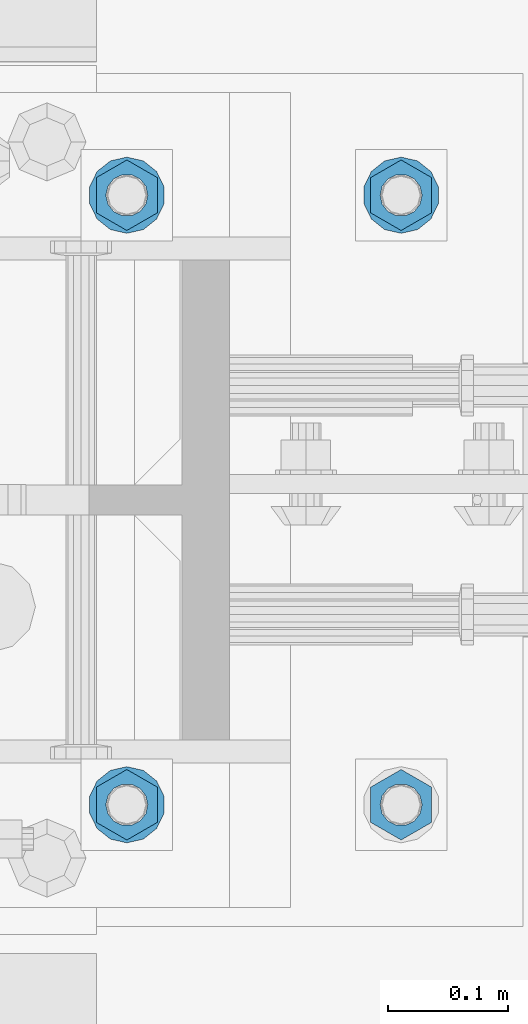
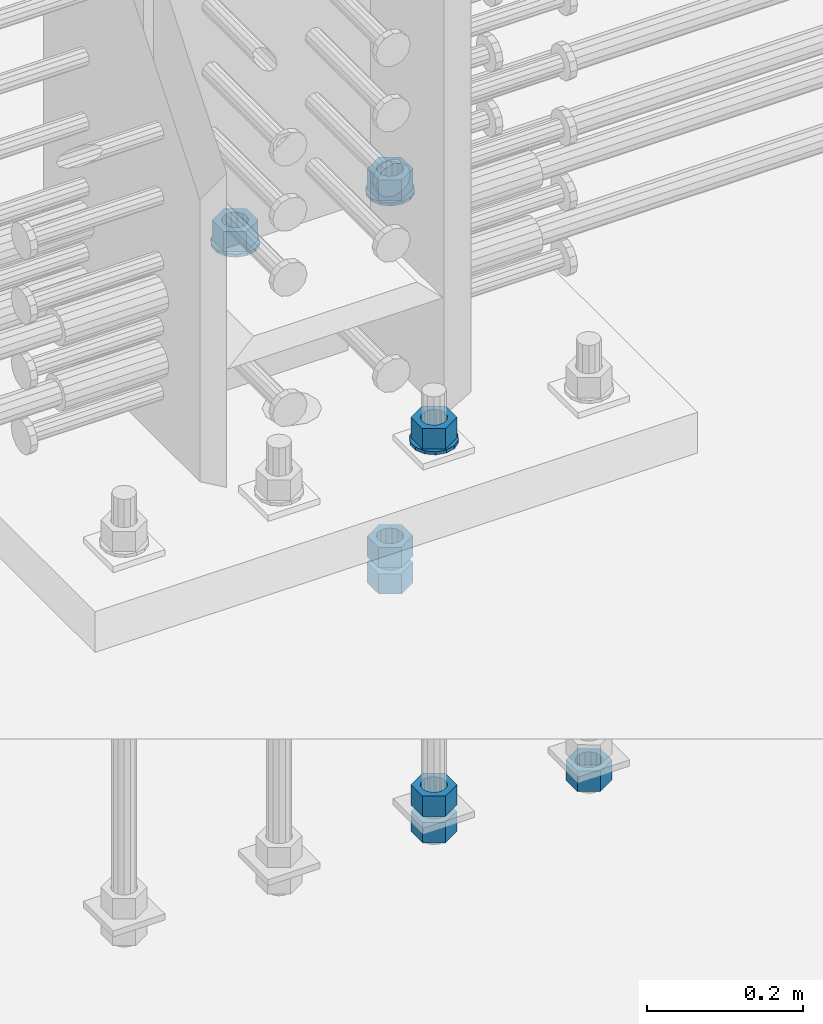
# One storey, part 1004 of 1763: 11 columns, 1 element without a shape of its own.
"""IFC2X3 building model written with IfcOpenShell, lengths in millimetres."""

import ifcopenshell
import ifcopenshell.guid

model = None  # the IFC model being written
_history = None  # IfcOwnerHistory: only IFC2X3 demands one
_inside = {}  # id of a spatial element -> (the spatial element, [elements in it])
_under = {}  # id of a project, library or spatial element -> (it, [spatial elements below it])
_declared = {}  # id of a project -> (the project, [libraries it declares])
_typed = {}  # id of a type object -> (the type object, [elements of that type])
_made_of = {}  # id of a material, layer set ... -> (it, [elements and type objects made of it])


def new_model(schema):
    """Start an empty IFC model of exactly this schema.

    Asked for "IFC4X3", IfcOpenShell would pick the latest addendum, in which some entities
    have other attributes; the version numbers below select the first issue.
    IFC2X3 requires an IfcOwnerHistory on every rooted entity: one is made here for all.
    """
    global model, _history
    if schema == "IFC4X3":
        model = ifcopenshell.file(schema_version=(4, 3, 0, 0))
    else:
        model = ifcopenshell.file(schema=schema)
    _inside.clear()
    _under.clear()
    _declared.clear()
    _typed.clear()
    _made_of.clear()
    _history = None
    if model.schema == "IFC2X3":
        org = make("IfcOrganization", Name="unknown")
        user = make(
            "IfcPersonAndOrganization",
            ThePerson=make("IfcPerson", FamilyName="unknown"),
            TheOrganization=org,
        )
        app = make(
            "IfcApplication",
            ApplicationDeveloper=org,
            Version="unknown",
            ApplicationFullName="unknown",
            ApplicationIdentifier="unknown",
        )
        _history = make(
            "IfcOwnerHistory",
            OwningUser=user,
            OwningApplication=app,
            ChangeAction="ADDED",
            CreationDate=0,
        )
    return model


def make(cls, **values):
    """One entity of the class cls with the attributes given. An attribute that is None is left unset."""
    return model.create_entity(
        cls, **{name: value for name, value in values.items() if value is not None}
    )


def rooted(cls, **values):
    """An entity with a GlobalId (a new one), such as an element, a storey or a relation."""
    return make(cls, GlobalId=ifcopenshell.guid.new(), OwnerHistory=_history, **values)


def si_unit(unit_type, name, prefix=None):
    """IfcSIUnit, for example si_unit("LENGTHUNIT", "METRE", prefix="MILLI")."""
    return make("IfcSIUnit", UnitType=unit_type, Prefix=prefix, Name=name)


def assignment(units):
    """IfcUnitAssignment: the units of a project."""
    return None if units is None else make("IfcUnitAssignment", Units=units)


def point(xyz):
    """IfcCartesianPoint."""
    return None if xyz is None else make("IfcCartesianPoint", Coordinates=xyz)


def direction(xyz):
    """IfcDirection."""
    return None if xyz is None else make("IfcDirection", DirectionRatios=xyz)


def frame(location, z_axis=None, x_axis=None):
    """IfcAxis2Placement3D, a coordinate frame: its origin and axes. An axis left out is left unset."""
    return make(
        "IfcAxis2Placement3D",
        Location=point(location),
        Axis=direction(z_axis),
        RefDirection=direction(x_axis),
    )


def origin_with_axes():
    """The frame at (0, 0, 0) with the z axis (0, 0, 1) and the x axis (1, 0, 0) written out."""
    return frame((0.0, 0.0, 0.0), z_axis=(0.0, 0.0, 1.0), x_axis=(1.0, 0.0, 0.0))


def place(relative_to, where):
    """IfcLocalPlacement: puts the frame where relative to a parent placement (None: the world)."""
    return make(
        "IfcLocalPlacement", PlacementRelTo=relative_to, RelativePlacement=where
    )


def context(
    kind, dimensions, precision=None, world=None, true_north=None, identifier=None
):
    """IfcGeometricRepresentationContext, for example the 3D "Model" context."""
    return make(
        "IfcGeometricRepresentationContext",
        ContextIdentifier=identifier,
        ContextType=kind,
        CoordinateSpaceDimension=dimensions,
        Precision=precision,
        WorldCoordinateSystem=world,
        TrueNorth=true_north,
    )


def subcontext(parent, identifier, kind, view, scale=None):
    """IfcGeometricRepresentationSubContext, for example "Body" below "Model"."""
    return make(
        "IfcGeometricRepresentationSubContext",
        ContextIdentifier=identifier,
        ContextType=kind,
        ParentContext=parent,
        TargetScale=scale,
        TargetView=view,
    )


def project(units=None, contexts=None):
    """IfcProject with its units and contexts."""
    return rooted(
        "IfcProject",
        Name="project",
        RepresentationContexts=contexts,
        UnitsInContext=assignment(units),
    )


def spatial(cls, under=None, at=None, **own):
    """A site, building, storey or space (cls), placed at a placement, below another one or the project."""
    s = rooted(cls, ObjectPlacement=at, **own)
    if under is not None:
        _under.setdefault(under.id(), (under, []))[1].append(s)
    return s


def faces_of(points, faces, orient=None, outer=None):
    """IfcFace entities. A face is a list of loops; a loop is a list of indices into points, from 0.

    orient and outer hold one flag for each loop. By default every Orientation is true, the
    first loop of a face is its IfcFaceOuterBound and the others are IfcFaceBound.
    """
    made = []
    for i, loops in enumerate(faces):
        bounds = []
        for j, loop in enumerate(loops):
            is_outer = j == 0 if outer is None else outer[i][j]
            bounds.append(
                make(
                    "IfcFaceOuterBound" if is_outer else "IfcFaceBound",
                    Bound=make("IfcPolyLoop", Polygon=[points[k] for k in loop]),
                    Orientation=True if orient is None else orient[i][j],
                )
            )
        made.append(make("IfcFace", Bounds=bounds))
    return made


def faceted_brep(points, faces, orient=None, outer=None, voids=None):
    """IfcFacetedBrep: a solid bounded by flat faces; with voids (closed shells), ...WithVoids."""
    shared = [point(p) for p in points]
    hull = make("IfcClosedShell", CfsFaces=faces_of(shared, faces, orient, outer))
    if voids is None:
        return make("IfcFacetedBrep", Outer=hull)
    return make(
        "IfcFacetedBrepWithVoids",
        Outer=hull,
        Voids=[
            make(cls, CfsFaces=faces_of(shared, fs, o, b)) for cls, fs, o, b in voids
        ],
    )


def shape(context_of_items, identifier, shape_type, items):
    """IfcShapeRepresentation: the items that make up one representation, for example the "Body"."""
    return make(
        "IfcShapeRepresentation",
        ContextOfItems=context_of_items,
        RepresentationIdentifier=identifier,
        RepresentationType=shape_type,
        Items=items,
    )


def material(Name=None, Category=None):
    """IfcMaterial."""
    return make("IfcMaterial", Name=Name, Category=Category)


def made_of(thing, what):
    """Note that an element or type object is made of a material, layer set ...; save() writes the relation."""
    if what is not None:
        _made_of.setdefault(what.id(), (what, []))[1].append(thing)
    return thing


def type_object(cls, material=None, **own):
    """A type object (cls), such as IfcWallType, which elements share."""
    return made_of(rooted(cls, **own), material)


def element(
    cls,
    number,
    at=None,
    inside=None,
    cuts=None,
    type_object=None,
    material=None,
    context=None,
    identifier="Body",
    shape_type=None,
    held_by="IfcProductDefinitionShape",
    body=None,
    shapes=None,
    **own,
):
    """One element of the class cls, such as IfcWall. Its Tag is "e" and its number.

    at: its placement. inside: the storey or other place that contains it. cuts: it is an
    opening in that element (IfcRelVoidsElement). A single representation is given by context,
    identifier, shape_type and body (its items); several are given by shapes. held_by: the class
    of the entity that holds the representations. save() writes the other relations.
    """
    e = rooted(cls, Tag="e%d" % number, ObjectPlacement=at, **own)
    if body is not None:
        shapes = [shape(context, identifier, shape_type, body)]
    if shapes is not None:
        e.Representation = make(held_by, Representations=shapes)
    if inside is not None:
        _inside.setdefault(inside.id(), (inside, []))[1].append(e)
    if cuts is not None:
        rooted(
            "IfcRelVoidsElement", RelatingBuildingElement=cuts, RelatedOpeningElement=e
        )
    if type_object is not None:
        _typed.setdefault(type_object.id(), (type_object, []))[1].append(e)
    return made_of(e, material)


def aggregate(whole, parts):
    """IfcRelAggregates: a whole, such as a stair, and the parts it consists of."""
    return rooted("IfcRelAggregates", RelatingObject=whole, RelatedObjects=parts)


def save(model, path):
    """Write the relations noted so far, then the file.

    IfcRelAggregates (storeys below a building ...), IfcRelContainedInSpatialStructure (elements
    in a storey), IfcRelDefinesByType, IfcRelAssociatesMaterial and IfcRelDeclares: one each for
    every whole, place, type object, material and project.
    """
    for whole, parts in _under.values():
        aggregate(whole, parts)
    for where, things in _inside.values():
        rooted(
            "IfcRelContainedInSpatialStructure",
            RelatedElements=things,
            RelatingStructure=where,
        )
    for kind, things in _typed.values():
        rooted("IfcRelDefinesByType", RelatedObjects=things, RelatingType=kind)
    for what, things in _made_of.values():
        rooted("IfcRelAssociatesMaterial", RelatedObjects=things, RelatingMaterial=what)
    for by, libraries in _declared.values():
        rooted("IfcRelDeclares", RelatingContext=by, RelatedDefinitions=libraries)
    model.write(path)


model = new_model("IFC2X3")

# Units and contexts
model_context = context("Model", 3, precision=1e-05, world=origin_with_axes())
body_context = subcontext(model_context, "Body", "Model", "MODEL_VIEW")
ifc_project = project(units=[si_unit("LENGTHUNIT", "METRE", prefix="MILLI"), si_unit("AREAUNIT", "SQUARE_METRE"), si_unit("VOLUMEUNIT", "CUBIC_METRE"), si_unit("MASSUNIT", "GRAM", prefix="KILO"), si_unit("TIMEUNIT", "SECOND"), si_unit("PLANEANGLEUNIT", "RADIAN"), si_unit("SOLIDANGLEUNIT", "STERADIAN"), si_unit("THERMODYNAMICTEMPERATUREUNIT", "DEGREE_CELSIUS"), si_unit("LUMINOUSINTENSITYUNIT", "LUMEN")], contexts=[model_context])

# Site, building, storey
site_placement = place(None, origin_with_axes())
site = spatial("IfcSite", under=ifc_project, at=site_placement, CompositionType="ELEMENT")
building_placement = place(site_placement, origin_with_axes())
building = spatial("IfcBuilding", under=site, at=building_placement, Name="Undefined", CompositionType="ELEMENT")
storey_placement = place(building_placement, origin_with_axes())
storey = spatial("IfcBuildingStorey", under=building, at=storey_placement, Name="Undefined", CompositionType="ELEMENT", Elevation=0.0)

# Assembly, columns
assembly_placement = place(storey_placement, origin_with_axes())
assembly = element("IfcElementAssembly", 1, at=assembly_placement, inside=storey, Name="TEMPLATE", AssemblyPlace="NOTDEFINED", PredefinedType="RIGID_FRAME")
ifc_material_1 = material(Name="STEEL/A563")
column_type_1 = type_object("IfcColumnType", Name="1-1/4_HEAVY_HEX_NUT", PredefinedType="NOTDEFINED")
column_1_placement = place(assembly_placement, frame((-34606.937273698, 203.199999999951, 3343.275), z_axis=(1.0, 0.0, 0.0), x_axis=(0.0, 0.0, -1.0)))
column_1 = element("IfcColumn", 2, at=column_1_placement, type_object=column_type_1, material=ifc_material_1, Name="NUT", ObjectType="1-1/4_HEAVY_HEX_NUT", context=body_context, shape_type="Brep", body=[
    faceted_brep([(0.0, -29.3700008392334, 0.0), (0.0, -14.6800003051758, -25.4300003051758), (31.75, -14.6800003051758, -25.4300003051758), (31.75, -29.3700008392334, 0.0), (0.0, 14.6800003051758, -25.4300003051758), (31.75, 14.6800003051758, -25.4300003051758), (0.0, 29.3700008392334, 0.0), (31.75, 29.3700008392334, 0.0), (0.0, 14.6800003051758, 25.4300003051758), (31.75, 14.6800003051758, 25.4300003051758), (0.0, -14.6800003051758, 25.4300003051758), (31.75, -14.6800003051758, 25.4300003051758), (0.0, 0.0, 17.4599990844727), (0.0, 7.57560968776022, 15.730915608714), (31.75, 7.57560968775942, 15.7309156087145), (31.75, 0.0, 17.4599990844727), (0.0, 13.6507769681037, 10.8861313696252), (31.75, 13.6507769681048, 10.8861313696314), (0.0, 17.0222404541215, 3.88521530314756), (31.75, 17.02224045412, 3.88521530315316), (0.0, 17.0222404541215, -3.88521530314756), (31.75, 17.02224045412, -3.88521530315332), (0.0, 13.6507769681037, -10.8861313696252), (31.75, 13.6507769681048, -10.8861313696316), (0.0, 7.57560968776022, -15.730915608714), (31.75, 7.57560968775942, -15.7309156087146), (0.0, 0.0, -17.4599990844727), (31.75, 0.0, -17.4599990844727), (0.0, -7.57560968776022, -15.730915608714), (31.75, -7.57560968775942, -15.7309156087145), (0.0, -13.6507769681037, -10.8861313696252), (31.75, -13.6507769681048, -10.8861313696314), (0.0, -17.0222404541215, -3.88521530314756), (31.75, -17.02224045412, -3.88521530315316), (0.0, -17.0222404541215, 3.88521530314756), (31.75, -17.02224045412, 3.88521530315332), (0.0, -13.6507769681037, 10.8861313696252), (31.75, -13.6507769681048, 10.8861313696316), (0.0, -7.57560968776022, 15.730915608714), (31.75, -7.57560968775942, 15.7309156087146)], [[[0, 1, 2, 3]], [[1, 4, 5, 2]], [[4, 6, 7, 5]], [[6, 8, 9, 7]], [[8, 10, 11, 9]], [[10, 0, 3, 11]], [[12, 13, 14, 15]], [[13, 16, 17, 14]], [[16, 18, 19, 17]], [[18, 20, 21, 19]], [[20, 22, 23, 21]], [[22, 24, 25, 23]], [[24, 26, 27, 25]], [[26, 28, 29, 27]], [[28, 30, 31, 29]], [[30, 32, 33, 31]], [[32, 34, 35, 33]], [[34, 36, 37, 35]], [[36, 38, 39, 37]], [[38, 12, 15, 39]], [[5, 7, 9, 11, 3, 2], [17, 19, 21, 23, 25, 27, 29, 31, 33, 35, 37, 39, 15, 14]], [[10, 8, 6, 4, 1, 0], [38, 36, 34, 32, 30, 28, 26, 24, 22, 20, 18, 16, 13, 12]]]),
])
column_2_placement = place(assembly_placement, frame((-34606.937273698, 711.199999999951, 3957.6375), z_axis=(-1.0, 0.0, 0.0), x_axis=(0.0, 0.0, -1.0)))
column_2 = element("IfcColumn", 3, at=column_2_placement, type_object=column_type_1, material=ifc_material_1, Name="NUT", ObjectType="1-1/4_HEAVY_HEX_NUT", context=body_context, shape_type="Brep", body=[
    faceted_brep([(0.0, -29.3700008392334, 0.0), (0.0, -14.6800003051758, -25.4300003051758), (31.75, -14.6800003051758, -25.4300003051758), (31.75, -29.3700008392334, 0.0), (0.0, 14.6800003051758, -25.4300003051758), (31.75, 14.6800003051758, -25.4300003051758), (0.0, 29.3700008392334, 0.0), (31.75, 29.3700008392334, 0.0), (0.0, 14.6800003051758, 25.4300003051758), (31.75, 14.6800003051758, 25.4300003051758), (0.0, -14.6800003051758, 25.4300003051758), (31.75, -14.6800003051758, 25.4300003051758), (0.0, 0.0, 17.4599990844727), (0.0, 7.57560968776022, 15.730915608714), (31.75, 7.57560968775942, 15.7309156087145), (31.75, 0.0, 17.4599990844727), (0.0, 13.6507769681037, 10.8861313696252), (31.75, 13.6507769681048, 10.8861313696314), (0.0, 17.0222404541215, 3.88521530314756), (31.75, 17.02224045412, 3.88521530315316), (0.0, 17.0222404541215, -3.88521530314756), (31.75, 17.02224045412, -3.88521530315332), (0.0, 13.6507769681037, -10.8861313696252), (31.75, 13.6507769681048, -10.8861313696316), (0.0, 7.57560968776022, -15.730915608714), (31.75, 7.57560968775942, -15.7309156087146), (0.0, 0.0, -17.4599990844727), (31.75, 0.0, -17.4599990844727), (0.0, -7.57560968776022, -15.730915608714), (31.75, -7.57560968775942, -15.7309156087145), (0.0, -13.6507769681037, -10.8861313696252), (31.75, -13.6507769681048, -10.8861313696314), (0.0, -17.0222404541215, -3.88521530314756), (31.75, -17.02224045412, -3.88521530315316), (0.0, -17.0222404541215, 3.88521530314756), (31.75, -17.02224045412, 3.88521530315332), (0.0, -13.6507769681037, 10.8861313696252), (31.75, -13.6507769681048, 10.8861313696316), (0.0, -7.57560968776022, 15.730915608714), (31.75, -7.57560968775942, 15.7309156087146)], [[[0, 1, 2, 3]], [[1, 4, 5, 2]], [[4, 6, 7, 5]], [[6, 8, 9, 7]], [[8, 10, 11, 9]], [[10, 0, 3, 11]], [[12, 13, 14, 15]], [[13, 16, 17, 14]], [[16, 18, 19, 17]], [[18, 20, 21, 19]], [[20, 22, 23, 21]], [[22, 24, 25, 23]], [[24, 26, 27, 25]], [[26, 28, 29, 27]], [[28, 30, 31, 29]], [[30, 32, 33, 31]], [[32, 34, 35, 33]], [[34, 36, 37, 35]], [[36, 38, 39, 37]], [[38, 12, 15, 39]], [[5, 7, 9, 11, 3, 2], [17, 19, 21, 23, 25, 27, 29, 31, 33, 35, 37, 39, 15, 14]], [[10, 8, 6, 4, 1, 0], [38, 36, 34, 32, 30, 28, 26, 24, 22, 20, 18, 16, 13, 12]]]),
])
column_3_placement = place(assembly_placement, frame((-34606.937273698, 711.199999999951, 3384.55), z_axis=(-1.0, 0.0, 0.0), x_axis=(0.0, 0.0, -1.0)))
column_3 = element("IfcColumn", 4, at=column_3_placement, type_object=column_type_1, material=ifc_material_1, Name="NUT", ObjectType="1-1/4_HEAVY_HEX_NUT", context=body_context, shape_type="Brep", body=[
    faceted_brep([(0.0, -29.3700008392334, 0.0), (0.0, -14.6800003051758, -25.4300003051758), (31.75, -14.6800003051758, -25.4300003051758), (31.75, -29.3700008392334, 0.0), (0.0, 14.6800003051758, -25.4300003051758), (31.75, 14.6800003051758, -25.4300003051758), (0.0, 29.3700008392334, 0.0), (31.75, 29.3700008392334, 0.0), (0.0, 14.6800003051758, 25.4300003051758), (31.75, 14.6800003051758, 25.4300003051758), (0.0, -14.6800003051758, 25.4300003051758), (31.75, -14.6800003051758, 25.4300003051758), (0.0, 0.0, 17.4599990844727), (0.0, 7.57560968776022, 15.730915608714), (31.75, 7.57560968775942, 15.7309156087145), (31.75, 0.0, 17.4599990844727), (0.0, 13.6507769681037, 10.8861313696252), (31.75, 13.6507769681048, 10.8861313696314), (0.0, 17.0222404541215, 3.88521530314756), (31.75, 17.02224045412, 3.88521530315316), (0.0, 17.0222404541215, -3.88521530314756), (31.75, 17.02224045412, -3.88521530315332), (0.0, 13.6507769681037, -10.8861313696252), (31.75, 13.6507769681048, -10.8861313696316), (0.0, 7.57560968776022, -15.730915608714), (31.75, 7.57560968775942, -15.7309156087146), (0.0, 0.0, -17.4599990844727), (31.75, 0.0, -17.4599990844727), (0.0, -7.57560968776022, -15.730915608714), (31.75, -7.57560968775942, -15.7309156087145), (0.0, -13.6507769681037, -10.8861313696252), (31.75, -13.6507769681048, -10.8861313696314), (0.0, -17.0222404541215, -3.88521530314756), (31.75, -17.02224045412, -3.88521530315316), (0.0, -17.0222404541215, 3.88521530314756), (31.75, -17.02224045412, 3.88521530315332), (0.0, -13.6507769681037, 10.8861313696252), (31.75, -13.6507769681048, 10.8861313696316), (0.0, -7.57560968776022, 15.730915608714), (31.75, -7.57560968775942, 15.7309156087146)], [[[0, 1, 2, 3]], [[1, 4, 5, 2]], [[4, 6, 7, 5]], [[6, 8, 9, 7]], [[8, 10, 11, 9]], [[10, 0, 3, 11]], [[12, 13, 14, 15]], [[13, 16, 17, 14]], [[16, 18, 19, 17]], [[18, 20, 21, 19]], [[20, 22, 23, 21]], [[22, 24, 25, 23]], [[24, 26, 27, 25]], [[26, 28, 29, 27]], [[28, 30, 31, 29]], [[30, 32, 33, 31]], [[32, 34, 35, 33]], [[34, 36, 37, 35]], [[36, 38, 39, 37]], [[38, 12, 15, 39]], [[5, 7, 9, 11, 3, 2], [17, 19, 21, 23, 25, 27, 29, 31, 33, 35, 37, 39, 15, 14]], [[10, 8, 6, 4, 1, 0], [38, 36, 34, 32, 30, 28, 26, 24, 22, 20, 18, 16, 13, 12]]]),
])
column_4_placement = place(assembly_placement, frame((-34606.937273698, 711.199999999951, 3343.275), z_axis=(-1.0, 0.0, 0.0), x_axis=(0.0, 0.0, -1.0)))
column_4 = element("IfcColumn", 5, at=column_4_placement, type_object=column_type_1, material=ifc_material_1, Name="NUT", ObjectType="1-1/4_HEAVY_HEX_NUT", context=body_context, shape_type="Brep", body=[
    faceted_brep([(0.0, -29.3700008392334, 0.0), (0.0, -14.6800003051758, -25.4300003051758), (31.75, -14.6800003051758, -25.4300003051758), (31.75, -29.3700008392334, 0.0), (0.0, 14.6800003051758, -25.4300003051758), (31.75, 14.6800003051758, -25.4300003051758), (0.0, 29.3700008392334, 0.0), (31.75, 29.3700008392334, 0.0), (0.0, 14.6800003051758, 25.4300003051758), (31.75, 14.6800003051758, 25.4300003051758), (0.0, -14.6800003051758, 25.4300003051758), (31.75, -14.6800003051758, 25.4300003051758), (0.0, 0.0, 17.4599990844727), (0.0, 7.57560968776022, 15.730915608714), (31.75, 7.57560968775942, 15.7309156087145), (31.75, 0.0, 17.4599990844727), (0.0, 13.6507769681037, 10.8861313696252), (31.75, 13.6507769681048, 10.8861313696314), (0.0, 17.0222404541215, 3.88521530314756), (31.75, 17.02224045412, 3.88521530315316), (0.0, 17.0222404541215, -3.88521530314756), (31.75, 17.02224045412, -3.88521530315332), (0.0, 13.6507769681037, -10.8861313696252), (31.75, 13.6507769681048, -10.8861313696316), (0.0, 7.57560968776022, -15.730915608714), (31.75, 7.57560968775942, -15.7309156087146), (0.0, 0.0, -17.4599990844727), (31.75, 0.0, -17.4599990844727), (0.0, -7.57560968776022, -15.730915608714), (31.75, -7.57560968775942, -15.7309156087145), (0.0, -13.6507769681037, -10.8861313696252), (31.75, -13.6507769681048, -10.8861313696314), (0.0, -17.0222404541215, -3.88521530314756), (31.75, -17.02224045412, -3.88521530315316), (0.0, -17.0222404541215, 3.88521530314756), (31.75, -17.02224045412, 3.88521530315332), (0.0, -13.6507769681037, 10.8861313696252), (31.75, -13.6507769681048, 10.8861313696316), (0.0, -7.57560968776022, 15.730915608714), (31.75, -7.57560968775942, 15.7309156087146)], [[[0, 1, 2, 3]], [[1, 4, 5, 2]], [[4, 6, 7, 5]], [[6, 8, 9, 7]], [[8, 10, 11, 9]], [[10, 0, 3, 11]], [[12, 13, 14, 15]], [[13, 16, 17, 14]], [[16, 18, 19, 17]], [[18, 20, 21, 19]], [[20, 22, 23, 21]], [[22, 24, 25, 23]], [[24, 26, 27, 25]], [[26, 28, 29, 27]], [[28, 30, 31, 29]], [[30, 32, 33, 31]], [[32, 34, 35, 33]], [[34, 36, 37, 35]], [[36, 38, 39, 37]], [[38, 12, 15, 39]], [[5, 7, 9, 11, 3, 2], [17, 19, 21, 23, 25, 27, 29, 31, 33, 35, 37, 39, 15, 14]], [[10, 8, 6, 4, 1, 0], [38, 36, 34, 32, 30, 28, 26, 24, 22, 20, 18, 16, 13, 12]]]),
])
column_5_placement = place(assembly_placement, frame((-34835.537273698, 203.199999999951, 3957.6375), z_axis=(1.0, 0.0, 0.0), x_axis=(0.0, 0.0, -1.0)))
column_5 = element("IfcColumn", 6, at=column_5_placement, type_object=column_type_1, material=ifc_material_1, Name="NUT", ObjectType="1-1/4_HEAVY_HEX_NUT", context=body_context, shape_type="Brep", body=[
    faceted_brep([(0.0, -29.3700008392334, 0.0), (0.0, -14.6800003051758, -25.4300003051758), (31.75, -14.6800003051758, -25.4300003051758), (31.75, -29.3700008392334, 0.0), (0.0, 14.6800003051758, -25.4300003051758), (31.75, 14.6800003051758, -25.4300003051758), (0.0, 29.3700008392334, 0.0), (31.75, 29.3700008392334, 0.0), (0.0, 14.6800003051758, 25.4300003051758), (31.75, 14.6800003051758, 25.4300003051758), (0.0, -14.6800003051758, 25.4300003051758), (31.75, -14.6800003051758, 25.4300003051758), (0.0, 0.0, 17.4599990844727), (0.0, 7.57560968776022, 15.730915608714), (31.75, 7.57560968775942, 15.7309156087145), (31.75, 0.0, 17.4599990844727), (0.0, 13.6507769681037, 10.8861313696252), (31.75, 13.6507769681048, 10.8861313696314), (0.0, 17.0222404541215, 3.88521530314756), (31.75, 17.02224045412, 3.88521530315316), (0.0, 17.0222404541215, -3.88521530314756), (31.75, 17.02224045412, -3.88521530315332), (0.0, 13.6507769681037, -10.8861313696252), (31.75, 13.6507769681048, -10.8861313696316), (0.0, 7.57560968776022, -15.730915608714), (31.75, 7.57560968775942, -15.7309156087146), (0.0, 0.0, -17.4599990844727), (31.75, 0.0, -17.4599990844727), (0.0, -7.57560968776022, -15.730915608714), (31.75, -7.57560968775942, -15.7309156087145), (0.0, -13.6507769681037, -10.8861313696252), (31.75, -13.6507769681048, -10.8861313696314), (0.0, -17.0222404541215, -3.88521530314756), (31.75, -17.02224045412, -3.88521530315316), (0.0, -17.0222404541215, 3.88521530314756), (31.75, -17.02224045412, 3.88521530315332), (0.0, -13.6507769681037, 10.8861313696252), (31.75, -13.6507769681048, 10.8861313696316), (0.0, -7.57560968776022, 15.730915608714), (31.75, -7.57560968775942, 15.7309156087146)], [[[0, 1, 2, 3]], [[1, 4, 5, 2]], [[4, 6, 7, 5]], [[6, 8, 9, 7]], [[8, 10, 11, 9]], [[10, 0, 3, 11]], [[12, 13, 14, 15]], [[13, 16, 17, 14]], [[16, 18, 19, 17]], [[18, 20, 21, 19]], [[20, 22, 23, 21]], [[22, 24, 25, 23]], [[24, 26, 27, 25]], [[26, 28, 29, 27]], [[28, 30, 31, 29]], [[30, 32, 33, 31]], [[32, 34, 35, 33]], [[34, 36, 37, 35]], [[36, 38, 39, 37]], [[38, 12, 15, 39]], [[5, 7, 9, 11, 3, 2], [17, 19, 21, 23, 25, 27, 29, 31, 33, 35, 37, 39, 15, 14]], [[10, 8, 6, 4, 1, 0], [38, 36, 34, 32, 30, 28, 26, 24, 22, 20, 18, 16, 13, 12]]]),
])
column_6_placement = place(assembly_placement, frame((-34835.537273698, 203.199999999951, 3384.55), z_axis=(1.0, 0.0, 0.0), x_axis=(0.0, 0.0, -1.0)))
column_6 = element("IfcColumn", 7, at=column_6_placement, type_object=column_type_1, material=ifc_material_1, Name="NUT", ObjectType="1-1/4_HEAVY_HEX_NUT", context=body_context, shape_type="Brep", body=[
    faceted_brep([(0.0, -29.3700008392334, 0.0), (0.0, -14.6800003051758, -25.4300003051758), (31.75, -14.6800003051758, -25.4300003051758), (31.75, -29.3700008392334, 0.0), (0.0, 14.6800003051758, -25.4300003051758), (31.75, 14.6800003051758, -25.4300003051758), (0.0, 29.3700008392334, 0.0), (31.75, 29.3700008392334, 0.0), (0.0, 14.6800003051758, 25.4300003051758), (31.75, 14.6800003051758, 25.4300003051758), (0.0, -14.6800003051758, 25.4300003051758), (31.75, -14.6800003051758, 25.4300003051758), (0.0, 0.0, 17.4599990844727), (0.0, 7.57560968776022, 15.730915608714), (31.75, 7.57560968775942, 15.7309156087145), (31.75, 0.0, 17.4599990844727), (0.0, 13.6507769681037, 10.8861313696252), (31.75, 13.6507769681048, 10.8861313696314), (0.0, 17.0222404541215, 3.88521530314756), (31.75, 17.02224045412, 3.88521530315316), (0.0, 17.0222404541215, -3.88521530314756), (31.75, 17.02224045412, -3.88521530315332), (0.0, 13.6507769681037, -10.8861313696252), (31.75, 13.6507769681048, -10.8861313696316), (0.0, 7.57560968776022, -15.730915608714), (31.75, 7.57560968775942, -15.7309156087146), (0.0, 0.0, -17.4599990844727), (31.75, 0.0, -17.4599990844727), (0.0, -7.57560968776022, -15.730915608714), (31.75, -7.57560968775942, -15.7309156087145), (0.0, -13.6507769681037, -10.8861313696252), (31.75, -13.6507769681048, -10.8861313696314), (0.0, -17.0222404541215, -3.88521530314756), (31.75, -17.02224045412, -3.88521530315316), (0.0, -17.0222404541215, 3.88521530314756), (31.75, -17.02224045412, 3.88521530315332), (0.0, -13.6507769681037, 10.8861313696252), (31.75, -13.6507769681048, 10.8861313696316), (0.0, -7.57560968776022, 15.730915608714), (31.75, -7.57560968775942, 15.7309156087146)], [[[0, 1, 2, 3]], [[1, 4, 5, 2]], [[4, 6, 7, 5]], [[6, 8, 9, 7]], [[8, 10, 11, 9]], [[10, 0, 3, 11]], [[12, 13, 14, 15]], [[13, 16, 17, 14]], [[16, 18, 19, 17]], [[18, 20, 21, 19]], [[20, 22, 23, 21]], [[22, 24, 25, 23]], [[24, 26, 27, 25]], [[26, 28, 29, 27]], [[28, 30, 31, 29]], [[30, 32, 33, 31]], [[32, 34, 35, 33]], [[34, 36, 37, 35]], [[36, 38, 39, 37]], [[38, 12, 15, 39]], [[5, 7, 9, 11, 3, 2], [17, 19, 21, 23, 25, 27, 29, 31, 33, 35, 37, 39, 15, 14]], [[10, 8, 6, 4, 1, 0], [38, 36, 34, 32, 30, 28, 26, 24, 22, 20, 18, 16, 13, 12]]]),
])
column_7_placement = place(assembly_placement, frame((-34835.537273698, 203.199999999951, 3343.275), z_axis=(1.0, 0.0, 0.0), x_axis=(0.0, 0.0, -1.0)))
column_7 = element("IfcColumn", 8, at=column_7_placement, type_object=column_type_1, material=ifc_material_1, Name="NUT", ObjectType="1-1/4_HEAVY_HEX_NUT", context=body_context, shape_type="Brep", body=[
    faceted_brep([(0.0, -29.3700008392334, 0.0), (0.0, -14.6800003051758, -25.4300003051758), (31.75, -14.6800003051758, -25.4300003051758), (31.75, -29.3700008392334, 0.0), (0.0, 14.6800003051758, -25.4300003051758), (31.75, 14.6800003051758, -25.4300003051758), (0.0, 29.3700008392334, 0.0), (31.75, 29.3700008392334, 0.0), (0.0, 14.6800003051758, 25.4300003051758), (31.75, 14.6800003051758, 25.4300003051758), (0.0, -14.6800003051758, 25.4300003051758), (31.75, -14.6800003051758, 25.4300003051758), (0.0, 0.0, 17.4599990844727), (0.0, 7.57560968776022, 15.730915608714), (31.75, 7.57560968775942, 15.7309156087145), (31.75, 0.0, 17.4599990844727), (0.0, 13.6507769681037, 10.8861313696252), (31.75, 13.6507769681048, 10.8861313696314), (0.0, 17.0222404541215, 3.88521530314756), (31.75, 17.02224045412, 3.88521530315316), (0.0, 17.0222404541215, -3.88521530314756), (31.75, 17.02224045412, -3.88521530315332), (0.0, 13.6507769681037, -10.8861313696252), (31.75, 13.6507769681048, -10.8861313696316), (0.0, 7.57560968776022, -15.730915608714), (31.75, 7.57560968775942, -15.7309156087146), (0.0, 0.0, -17.4599990844727), (31.75, 0.0, -17.4599990844727), (0.0, -7.57560968776022, -15.730915608714), (31.75, -7.57560968775942, -15.7309156087145), (0.0, -13.6507769681037, -10.8861313696252), (31.75, -13.6507769681048, -10.8861313696314), (0.0, -17.0222404541215, -3.88521530314756), (31.75, -17.02224045412, -3.88521530315316), (0.0, -17.0222404541215, 3.88521530314756), (31.75, -17.02224045412, 3.88521530315332), (0.0, -13.6507769681037, 10.8861313696252), (31.75, -13.6507769681048, 10.8861313696316), (0.0, -7.57560968776022, 15.730915608714), (31.75, -7.57560968775942, 15.7309156087146)], [[[0, 1, 2, 3]], [[1, 4, 5, 2]], [[4, 6, 7, 5]], [[6, 8, 9, 7]], [[8, 10, 11, 9]], [[10, 0, 3, 11]], [[12, 13, 14, 15]], [[13, 16, 17, 14]], [[16, 18, 19, 17]], [[18, 20, 21, 19]], [[20, 22, 23, 21]], [[22, 24, 25, 23]], [[24, 26, 27, 25]], [[26, 28, 29, 27]], [[28, 30, 31, 29]], [[30, 32, 33, 31]], [[32, 34, 35, 33]], [[34, 36, 37, 35]], [[36, 38, 39, 37]], [[38, 12, 15, 39]], [[5, 7, 9, 11, 3, 2], [17, 19, 21, 23, 25, 27, 29, 31, 33, 35, 37, 39, 15, 14]], [[10, 8, 6, 4, 1, 0], [38, 36, 34, 32, 30, 28, 26, 24, 22, 20, 18, 16, 13, 12]]]),
])
column_8_placement = place(assembly_placement, frame((-34835.537273698, 711.199999999951, 3957.6375), z_axis=(-1.0, 0.0, 0.0), x_axis=(0.0, 0.0, -1.0)))
column_8 = element("IfcColumn", 9, at=column_8_placement, type_object=column_type_1, material=ifc_material_1, Name="NUT", ObjectType="1-1/4_HEAVY_HEX_NUT", context=body_context, shape_type="Brep", body=[
    faceted_brep([(0.0, -29.3700008392334, 0.0), (0.0, -14.6800003051758, -25.4300003051758), (31.75, -14.6800003051758, -25.4300003051758), (31.75, -29.3700008392334, 0.0), (0.0, 14.6800003051758, -25.4300003051758), (31.75, 14.6800003051758, -25.4300003051758), (0.0, 29.3700008392334, 0.0), (31.75, 29.3700008392334, 0.0), (0.0, 14.6800003051758, 25.4300003051758), (31.75, 14.6800003051758, 25.4300003051758), (0.0, -14.6800003051758, 25.4300003051758), (31.75, -14.6800003051758, 25.4300003051758), (0.0, 0.0, 17.4599990844727), (0.0, 7.57560968776022, 15.730915608714), (31.75, 7.57560968775942, 15.7309156087145), (31.75, 0.0, 17.4599990844727), (0.0, 13.6507769681037, 10.8861313696252), (31.75, 13.6507769681048, 10.8861313696314), (0.0, 17.0222404541215, 3.88521530314756), (31.75, 17.02224045412, 3.88521530315316), (0.0, 17.0222404541215, -3.88521530314756), (31.75, 17.02224045412, -3.88521530315332), (0.0, 13.6507769681037, -10.8861313696252), (31.75, 13.6507769681048, -10.8861313696316), (0.0, 7.57560968776022, -15.730915608714), (31.75, 7.57560968775942, -15.7309156087146), (0.0, 0.0, -17.4599990844727), (31.75, 0.0, -17.4599990844727), (0.0, -7.57560968776022, -15.730915608714), (31.75, -7.57560968775942, -15.7309156087145), (0.0, -13.6507769681037, -10.8861313696252), (31.75, -13.6507769681048, -10.8861313696314), (0.0, -17.0222404541215, -3.88521530314756), (31.75, -17.02224045412, -3.88521530315316), (0.0, -17.0222404541215, 3.88521530314756), (31.75, -17.02224045412, 3.88521530315332), (0.0, -13.6507769681037, 10.8861313696252), (31.75, -13.6507769681048, 10.8861313696316), (0.0, -7.57560968776022, 15.730915608714), (31.75, -7.57560968775942, 15.7309156087146)], [[[0, 1, 2, 3]], [[1, 4, 5, 2]], [[4, 6, 7, 5]], [[6, 8, 9, 7]], [[8, 10, 11, 9]], [[10, 0, 3, 11]], [[12, 13, 14, 15]], [[13, 16, 17, 14]], [[16, 18, 19, 17]], [[18, 20, 21, 19]], [[20, 22, 23, 21]], [[22, 24, 25, 23]], [[24, 26, 27, 25]], [[26, 28, 29, 27]], [[28, 30, 31, 29]], [[30, 32, 33, 31]], [[32, 34, 35, 33]], [[34, 36, 37, 35]], [[36, 38, 39, 37]], [[38, 12, 15, 39]], [[5, 7, 9, 11, 3, 2], [17, 19, 21, 23, 25, 27, 29, 31, 33, 35, 37, 39, 15, 14]], [[10, 8, 6, 4, 1, 0], [38, 36, 34, 32, 30, 28, 26, 24, 22, 20, 18, 16, 13, 12]]]),
])
ifc_material_2 = material(Name="STEEL/F436")
column_type_2 = type_object("IfcColumnType", Name="1-1/4_WASHER", PredefinedType="NOTDEFINED")
column_9_placement = place(assembly_placement, frame((-34606.937273698, 711.199999999951, 3925.8875), z_axis=(-1.0, 0.0, 0.0), x_axis=(0.0, 0.0, -1.0)))
column_9 = element("IfcColumn", 10, at=column_9_placement, type_object=column_type_2, material=ifc_material_2, Name="WASHER", ObjectType="1-1/4_WASHER", context=body_context, shape_type="Brep", body=[
    faceted_brep([(-4.54747350886464e-13, -31.7499999999964, 0.0), (0.0, -28.6057615559002, -13.7758087169827), (4.76249999999982, -28.6057615559002, -13.7758087169827), (4.76249999999982, -31.75, 0.0), (0.0, -19.795801209013, -24.8231495683602), (4.76249999999982, -19.795801209013, -24.8231495683602), (0.0, -7.06503965311276, -30.9539612117732), (4.76249999999982, -7.06503965311276, -30.9539612117732), (0.0, 7.06503965311276, -30.9539612117732), (4.76249999999982, 7.06503965311276, -30.9539612117732), (0.0, 19.7958012090166, -24.8231495683602), (4.76249999999982, 19.7958012090166, -24.8231495683602), (0.0, 28.6057615559039, -13.7758087169827), (4.76249999999982, 28.6057615559039, -13.7758087169827), (-5.91171556152403e-12, 31.7499999999891, 0.0), (4.76249999999982, 31.75, 0.0), (0.0, 28.6057615559002, 13.7758087169827), (4.76249999999982, 28.6057615559002, 13.7758087169827), (0.0, 19.795801209013, 24.8231495683602), (4.76249999999982, 19.795801209013, 24.8231495683602), (0.0, 7.06503965311276, 30.9539612117731), (4.76249999999982, 7.06503965311276, 30.9539612117731), (0.0, -7.06503965311276, 30.9539612117731), (4.76249999999982, -7.06503965311276, 30.9539612117731), (0.0, -19.7958012090166, 24.8231495683602), (4.76249999999982, -19.7958012090166, 24.8231495683602), (0.0, -28.6057615559039, 13.7758087169827), (4.76249999999982, -28.6057615559039, 13.7758087169827), (0.0, 0.0, 17.4599990844727), (0.0, 7.57560968776022, 15.730915608714), (4.76249999999982, 7.57560968775942, 15.7309156087145), (4.76249999999982, 0.0, 17.4599990844727), (0.0, 13.6507769681037, 10.8861313696252), (4.76249999999982, 13.6507769681048, 10.8861313696314), (0.0, 17.0222404541215, 3.88521530314756), (4.76249999999982, 17.02224045412, 3.88521530315316), (0.0, 17.0222404541215, -3.88521530314756), (4.76249999999982, 17.02224045412, -3.88521530315332), (0.0, 13.6507769681037, -10.8861313696252), (4.76249999999982, 13.6507769681048, -10.8861313696316), (0.0, 7.57560968776022, -15.730915608714), (4.76249999999982, 7.57560968775942, -15.7309156087146), (0.0, 0.0, -17.4599990844727), (4.76249999999982, 0.0, -17.4599990844727), (0.0, -7.57560968776022, -15.730915608714), (4.76249999999982, -7.57560968775942, -15.7309156087145), (0.0, -13.6507769681037, -10.8861313696252), (4.76249999999982, -13.6507769681048, -10.8861313696314), (0.0, -17.0222404541215, -3.88521530314756), (4.76249999999982, -17.02224045412, -3.88521530315316), (0.0, -17.0222404541215, 3.88521530314756), (4.76249999999982, -17.02224045412, 3.88521530315332), (0.0, -13.6507769681037, 10.8861313696252), (4.76249999999982, -13.6507769681048, 10.8861313696316), (0.0, -7.57560968776022, 15.730915608714), (4.76249999999982, -7.57560968775942, 15.7309156087146)], [[[0, 1, 2, 3]], [[1, 4, 5, 2]], [[4, 6, 7, 5]], [[6, 8, 9, 7]], [[8, 10, 11, 9]], [[10, 12, 13, 11]], [[12, 14, 15, 13]], [[14, 16, 17, 15]], [[16, 18, 19, 17]], [[18, 20, 21, 19]], [[20, 22, 23, 21]], [[22, 24, 25, 23]], [[24, 26, 27, 25]], [[26, 0, 3, 27]], [[28, 29, 30, 31]], [[29, 32, 33, 30]], [[32, 34, 35, 33]], [[34, 36, 37, 35]], [[36, 38, 39, 37]], [[38, 40, 41, 39]], [[40, 42, 43, 41]], [[42, 44, 45, 43]], [[44, 46, 47, 45]], [[46, 48, 49, 47]], [[48, 50, 51, 49]], [[50, 52, 53, 51]], [[52, 54, 55, 53]], [[54, 28, 31, 55]], [[5, 7, 9, 11, 13, 15, 17, 19, 21, 23, 25, 27, 3, 2], [33, 35, 37, 39, 41, 43, 45, 47, 49, 51, 53, 55, 31, 30]], [[26, 24, 22, 20, 18, 16, 14, 12, 10, 8, 6, 4, 1, 0], [54, 52, 50, 48, 46, 44, 42, 40, 38, 36, 34, 32, 29, 28]]]),
])
column_10_placement = place(assembly_placement, frame((-34835.537273698, 203.199999999951, 3925.8875), z_axis=(1.0, 0.0, 0.0), x_axis=(0.0, 0.0, -1.0)))
column_10 = element("IfcColumn", 11, at=column_10_placement, type_object=column_type_2, material=ifc_material_2, Name="WASHER", ObjectType="1-1/4_WASHER", context=body_context, shape_type="Brep", body=[
    faceted_brep([(-4.54747350886464e-13, -31.7499999999964, 0.0), (0.0, -28.6057615559002, -13.7758087169827), (4.76249999999982, -28.6057615559002, -13.7758087169827), (4.76249999999982, -31.75, 0.0), (0.0, -19.795801209013, -24.8231495683602), (4.76249999999982, -19.795801209013, -24.8231495683602), (0.0, -7.06503965311276, -30.9539612117732), (4.76249999999982, -7.06503965311276, -30.9539612117732), (0.0, 7.06503965311276, -30.9539612117732), (4.76249999999982, 7.06503965311276, -30.9539612117732), (0.0, 19.7958012090166, -24.8231495683602), (4.76249999999982, 19.7958012090166, -24.8231495683602), (0.0, 28.6057615559039, -13.7758087169827), (4.76249999999982, 28.6057615559039, -13.7758087169827), (-5.91171556152403e-12, 31.7499999999891, 0.0), (4.76249999999982, 31.75, 0.0), (0.0, 28.6057615559002, 13.7758087169827), (4.76249999999982, 28.6057615559002, 13.7758087169827), (0.0, 19.795801209013, 24.8231495683602), (4.76249999999982, 19.795801209013, 24.8231495683602), (0.0, 7.06503965311276, 30.9539612117731), (4.76249999999982, 7.06503965311276, 30.9539612117731), (0.0, -7.06503965311276, 30.9539612117731), (4.76249999999982, -7.06503965311276, 30.9539612117731), (0.0, -19.7958012090166, 24.8231495683602), (4.76249999999982, -19.7958012090166, 24.8231495683602), (0.0, -28.6057615559039, 13.7758087169827), (4.76249999999982, -28.6057615559039, 13.7758087169827), (0.0, 0.0, 17.4599990844727), (0.0, 7.57560968776022, 15.730915608714), (4.76249999999982, 7.57560968775942, 15.7309156087145), (4.76249999999982, 0.0, 17.4599990844727), (0.0, 13.6507769681037, 10.8861313696252), (4.76249999999982, 13.6507769681048, 10.8861313696314), (0.0, 17.0222404541215, 3.88521530314756), (4.76249999999982, 17.02224045412, 3.88521530315316), (0.0, 17.0222404541215, -3.88521530314756), (4.76249999999982, 17.02224045412, -3.88521530315332), (0.0, 13.6507769681037, -10.8861313696252), (4.76249999999982, 13.6507769681048, -10.8861313696316), (0.0, 7.57560968776022, -15.730915608714), (4.76249999999982, 7.57560968775942, -15.7309156087146), (0.0, 0.0, -17.4599990844727), (4.76249999999982, 0.0, -17.4599990844727), (0.0, -7.57560968776022, -15.730915608714), (4.76249999999982, -7.57560968775942, -15.7309156087145), (0.0, -13.6507769681037, -10.8861313696252), (4.76249999999982, -13.6507769681048, -10.8861313696314), (0.0, -17.0222404541215, -3.88521530314756), (4.76249999999982, -17.02224045412, -3.88521530315316), (0.0, -17.0222404541215, 3.88521530314756), (4.76249999999982, -17.02224045412, 3.88521530315332), (0.0, -13.6507769681037, 10.8861313696252), (4.76249999999982, -13.6507769681048, 10.8861313696316), (0.0, -7.57560968776022, 15.730915608714), (4.76249999999982, -7.57560968775942, 15.7309156087146)], [[[0, 1, 2, 3]], [[1, 4, 5, 2]], [[4, 6, 7, 5]], [[6, 8, 9, 7]], [[8, 10, 11, 9]], [[10, 12, 13, 11]], [[12, 14, 15, 13]], [[14, 16, 17, 15]], [[16, 18, 19, 17]], [[18, 20, 21, 19]], [[20, 22, 23, 21]], [[22, 24, 25, 23]], [[24, 26, 27, 25]], [[26, 0, 3, 27]], [[28, 29, 30, 31]], [[29, 32, 33, 30]], [[32, 34, 35, 33]], [[34, 36, 37, 35]], [[36, 38, 39, 37]], [[38, 40, 41, 39]], [[40, 42, 43, 41]], [[42, 44, 45, 43]], [[44, 46, 47, 45]], [[46, 48, 49, 47]], [[48, 50, 51, 49]], [[50, 52, 53, 51]], [[52, 54, 55, 53]], [[54, 28, 31, 55]], [[5, 7, 9, 11, 13, 15, 17, 19, 21, 23, 25, 27, 3, 2], [33, 35, 37, 39, 41, 43, 45, 47, 49, 51, 53, 55, 31, 30]], [[26, 24, 22, 20, 18, 16, 14, 12, 10, 8, 6, 4, 1, 0], [54, 52, 50, 48, 46, 44, 42, 40, 38, 36, 34, 32, 29, 28]]]),
])
column_11_placement = place(assembly_placement, frame((-34835.537273698, 711.199999999951, 3925.8875), z_axis=(-1.0, 0.0, 0.0), x_axis=(0.0, 0.0, -1.0)))
column_11 = element("IfcColumn", 12, at=column_11_placement, type_object=column_type_2, material=ifc_material_2, Name="WASHER", ObjectType="1-1/4_WASHER", context=body_context, shape_type="Brep", body=[
    faceted_brep([(-4.54747350886464e-13, -31.7499999999964, 0.0), (0.0, -28.6057615559002, -13.7758087169827), (4.76249999999982, -28.6057615559002, -13.7758087169827), (4.76249999999982, -31.75, 0.0), (0.0, -19.795801209013, -24.8231495683602), (4.76249999999982, -19.795801209013, -24.8231495683602), (0.0, -7.06503965311276, -30.9539612117732), (4.76249999999982, -7.06503965311276, -30.9539612117732), (0.0, 7.06503965311276, -30.9539612117732), (4.76249999999982, 7.06503965311276, -30.9539612117732), (0.0, 19.7958012090166, -24.8231495683602), (4.76249999999982, 19.7958012090166, -24.8231495683602), (0.0, 28.6057615559039, -13.7758087169827), (4.76249999999982, 28.6057615559039, -13.7758087169827), (-5.91171556152403e-12, 31.7499999999891, 0.0), (4.76249999999982, 31.75, 0.0), (0.0, 28.6057615559002, 13.7758087169827), (4.76249999999982, 28.6057615559002, 13.7758087169827), (0.0, 19.795801209013, 24.8231495683602), (4.76249999999982, 19.795801209013, 24.8231495683602), (0.0, 7.06503965311276, 30.9539612117731), (4.76249999999982, 7.06503965311276, 30.9539612117731), (0.0, -7.06503965311276, 30.9539612117731), (4.76249999999982, -7.06503965311276, 30.9539612117731), (0.0, -19.7958012090166, 24.8231495683602), (4.76249999999982, -19.7958012090166, 24.8231495683602), (0.0, -28.6057615559039, 13.7758087169827), (4.76249999999982, -28.6057615559039, 13.7758087169827), (0.0, 0.0, 17.4599990844727), (0.0, 7.57560968776022, 15.730915608714), (4.76249999999982, 7.57560968775942, 15.7309156087145), (4.76249999999982, 0.0, 17.4599990844727), (0.0, 13.6507769681037, 10.8861313696252), (4.76249999999982, 13.6507769681048, 10.8861313696314), (0.0, 17.0222404541215, 3.88521530314756), (4.76249999999982, 17.02224045412, 3.88521530315316), (0.0, 17.0222404541215, -3.88521530314756), (4.76249999999982, 17.02224045412, -3.88521530315332), (0.0, 13.6507769681037, -10.8861313696252), (4.76249999999982, 13.6507769681048, -10.8861313696316), (0.0, 7.57560968776022, -15.730915608714), (4.76249999999982, 7.57560968775942, -15.7309156087146), (0.0, 0.0, -17.4599990844727), (4.76249999999982, 0.0, -17.4599990844727), (0.0, -7.57560968776022, -15.730915608714), (4.76249999999982, -7.57560968775942, -15.7309156087145), (0.0, -13.6507769681037, -10.8861313696252), (4.76249999999982, -13.6507769681048, -10.8861313696314), (0.0, -17.0222404541215, -3.88521530314756), (4.76249999999982, -17.02224045412, -3.88521530315316), (0.0, -17.0222404541215, 3.88521530314756), (4.76249999999982, -17.02224045412, 3.88521530315332), (0.0, -13.6507769681037, 10.8861313696252), (4.76249999999982, -13.6507769681048, 10.8861313696316), (0.0, -7.57560968776022, 15.730915608714), (4.76249999999982, -7.57560968775942, 15.7309156087146)], [[[0, 1, 2, 3]], [[1, 4, 5, 2]], [[4, 6, 7, 5]], [[6, 8, 9, 7]], [[8, 10, 11, 9]], [[10, 12, 13, 11]], [[12, 14, 15, 13]], [[14, 16, 17, 15]], [[16, 18, 19, 17]], [[18, 20, 21, 19]], [[20, 22, 23, 21]], [[22, 24, 25, 23]], [[24, 26, 27, 25]], [[26, 0, 3, 27]], [[28, 29, 30, 31]], [[29, 32, 33, 30]], [[32, 34, 35, 33]], [[34, 36, 37, 35]], [[36, 38, 39, 37]], [[38, 40, 41, 39]], [[40, 42, 43, 41]], [[42, 44, 45, 43]], [[44, 46, 47, 45]], [[46, 48, 49, 47]], [[48, 50, 51, 49]], [[50, 52, 53, 51]], [[52, 54, 55, 53]], [[54, 28, 31, 55]], [[5, 7, 9, 11, 13, 15, 17, 19, 21, 23, 25, 27, 3, 2], [33, 35, 37, 39, 41, 43, 45, 47, 49, 51, 53, 55, 31, 30]], [[26, 24, 22, 20, 18, 16, 14, 12, 10, 8, 6, 4, 1, 0], [54, 52, 50, 48, 46, 44, 42, 40, 38, 36, 34, 32, 29, 28]]]),
])
aggregate(assembly, [column_1, column_2, column_9, column_3, column_4, column_5, column_10, column_6, column_7, column_8, column_11])

save(model, "model.ifc")
